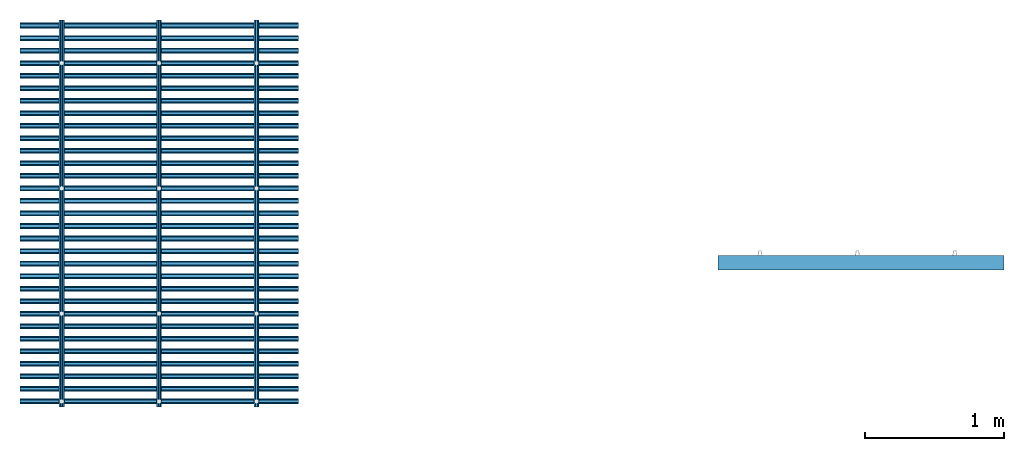
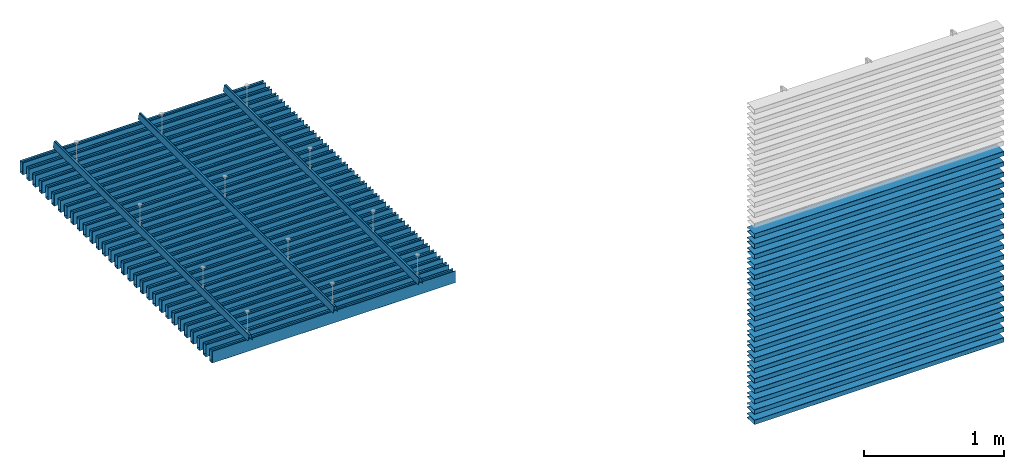
# One storey, part 1 of 3: 53 members, 3 elements without a shape of their own.
"""IFC2X3 building model written with IfcOpenShell, lengths in millimetres."""

from ifc_helpers import new_model, entity, si_unit, converted_unit, derived_unit, direction, frame, frame_2d, origin, place, context, subcontext, project, spatial, polyline, circle_curve, parameter, trimmed, segment, composite_curve, outline, extrude, source, transform, mapped, material, type_object, type_shapes, element, aggregate, save


model = new_model("IFC2X3")

# Units and contexts
model_context = context("Model", 3, precision=0.01, world=origin(), true_north=direction((6.12303176911189e-17, 1.0)))
body_context = subcontext(model_context, "Body", "Model", "MODEL_VIEW")
ifc_project = project(units=[si_unit("LENGTHUNIT", "METRE", prefix="MILLI"), si_unit("AREAUNIT", "SQUARE_METRE"), si_unit("VOLUMEUNIT", "CUBIC_METRE"), converted_unit("PLANEANGLEUNIT", "DEGREE", entity("IfcRatioMeasure", 0.0174532925199433), si_unit("PLANEANGLEUNIT", "RADIAN"), dimensions=[0, 0, 0, 0, 0, 0, 0]), si_unit("MASSUNIT", "GRAM", prefix="KILO"), derived_unit("MASSDENSITYUNIT", [(si_unit("MASSUNIT", "GRAM", prefix="KILO"), 1), (si_unit("LENGTHUNIT", "METRE"), -3)]), derived_unit("MOMENTOFINERTIAUNIT", [(si_unit("LENGTHUNIT", "METRE"), 4)]), si_unit("TIMEUNIT", "SECOND"), si_unit("FREQUENCYUNIT", "HERTZ"), si_unit("THERMODYNAMICTEMPERATUREUNIT", "DEGREE_CELSIUS"), derived_unit("THERMALTRANSMITTANCEUNIT", [(si_unit("MASSUNIT", "GRAM", prefix="KILO"), 1), (si_unit("THERMODYNAMICTEMPERATUREUNIT", "KELVIN"), -1), (si_unit("TIMEUNIT", "SECOND"), -3)]), derived_unit("VOLUMETRICFLOWRATEUNIT", [(si_unit("LENGTHUNIT", "METRE"), 3), (si_unit("TIMEUNIT", "SECOND"), -1)]), si_unit("ELECTRICCURRENTUNIT", "AMPERE"), si_unit("ELECTRICVOLTAGEUNIT", "VOLT"), si_unit("POWERUNIT", "WATT"), si_unit("FORCEUNIT", "NEWTON", prefix="KILO"), si_unit("ILLUMINANCEUNIT", "LUX"), si_unit("LUMINOUSFLUXUNIT", "LUMEN"), si_unit("LUMINOUSINTENSITYUNIT", "CANDELA"), derived_unit("USERDEFINED", [(si_unit("MASSUNIT", "GRAM", prefix="KILO"), -1), (si_unit("LENGTHUNIT", "METRE"), -2), (si_unit("TIMEUNIT", "SECOND"), 3), (si_unit("LUMINOUSFLUXUNIT", "LUMEN"), 1)]), derived_unit("LINEARVELOCITYUNIT", [(si_unit("LENGTHUNIT", "METRE"), 1), (si_unit("TIMEUNIT", "SECOND"), -1)]), si_unit("PRESSUREUNIT", "PASCAL"), derived_unit("USERDEFINED", [(si_unit("LENGTHUNIT", "METRE"), -2), (si_unit("MASSUNIT", "GRAM", prefix="KILO"), 1), (si_unit("TIMEUNIT", "SECOND"), -2)]), derived_unit("LINEARFORCEUNIT", [(si_unit("MASSUNIT", "GRAM", prefix="KILO"), 1), (si_unit("LENGTHUNIT", "METRE"), 1), (si_unit("TIMEUNIT", "SECOND"), -2), (si_unit("LENGTHUNIT", "METRE"), -1)]), derived_unit("PLANARFORCEUNIT", [(si_unit("MASSUNIT", "GRAM", prefix="KILO"), 1), (si_unit("LENGTHUNIT", "METRE"), 1), (si_unit("TIMEUNIT", "SECOND"), -2), (si_unit("LENGTHUNIT", "METRE"), -2)])], contexts=[model_context])

# Site, building, storey
site_placement = place(None, origin())
site = spatial("IfcSite", under=ifc_project, at=site_placement, CompositionType="ELEMENT")
building_placement = place(site_placement, origin())
building = spatial("IfcBuilding", under=site, at=building_placement, CompositionType="ELEMENT")
storey_placement = place(building_placement, origin())
storey = spatial("IfcBuildingStorey", under=building, at=storey_placement, Name="Level 1", CompositionType="ELEMENT", Elevation=0.0)

# Roof, members
curtain_wall_type_1 = type_object("IfcCurtainWallType", PredefinedType="NOTDEFINED")
roof_1_placement = place(storey_placement, origin())
roof_1 = element("IfcRoof", 1, at=roof_1_placement, inside=storey, type_object=curtain_wall_type_1, ShapeType="NOTDEFINED")
ifc_material = material(Name="NBS_PolyesterFibrePET_White")
member_type_1 = type_object("IfcMemberType", PredefinedType="MULLION", material=ifc_material)
shared_shape_1 = source(origin(), body_context, "Body", "SweptSolid", [
    extrude(outline(composite_curve([segment(polyline([(-58.2172353514992, -20.0), (41.5064366235799, -20.0)]), True, "CONTINUOUS"), segment(trimmed(circle_curve(frame_2d((41.5064366235799, -17.2947666541993), x_axis=(0.0, -1.0)), 2.70523334580068), [parameter(0.0)], [parameter(144.999999521531)], True, "PARAMETER"), True, "CONTINUOUS"), segment(polyline([(43.0580947440677, -15.0787692416656), (35.4091908097754, -9.72294895264017)]), True, "CONTINUOUS"), segment(polyline([(35.4091908097754, -9.72294895264017), (34.1473226498031, -11.525083450076)]), True, "CONTINUOUS"), segment(polyline([(34.1473226498031, -11.5250834500759), (41.0304174033758, -16.3446783684007)]), True, "CONTINUOUS"), segment(trimmed(circle_curve(frame_2d((40.5715562488225, -17.0), x_axis=(0.573576443191669, 0.819152039499135)), 0.800000000000003), [parameter(215.000000478469)], [parameter(0.0)], True, "PARAMETER"), False, "CONTINUOUS"), segment(polyline([(40.5715562488225, -17.8), (-57.9019277093083, -17.7999999999998)]), True, "CONTINUOUS"), segment(trimmed(circle_curve(frame_2d((-57.9019277093082, -17.0), x_axis=(0.0, -1.0)), 0.800000000000006), [parameter(270.000000000002)], [parameter(0.0)], True, "PARAMETER"), False, "CONTINUOUS"), segment(polyline([(-58.7019277093083, -17.0), (-58.7019277093082, 17.0)]), True, "CONTINUOUS"), segment(trimmed(circle_curve(frame_2d((-57.9019277093083, 17.0), x_axis=(-1.0, 0.0)), 0.800000000000007), [parameter(270.000000000002)], [parameter(0.0)], True, "PARAMETER"), False, "CONTINUOUS"), segment(polyline([(-57.9019277093083, 17.7999999999998), (40.5715562488224, 17.8)]), True, "CONTINUOUS"), segment(trimmed(circle_curve(frame_2d((40.5715562488224, 17.0), x_axis=(0.0, 1.0)), 0.8), [parameter(215.000000478469)], [parameter(0.0)], True, "PARAMETER"), False, "CONTINUOUS"), segment(polyline([(41.0304174033758, 16.3446783684007), (34.147322649803, 11.5250834500759)]), True, "CONTINUOUS"), segment(polyline([(34.147322649803, 11.5250834500759), (35.4091908097753, 9.72294895264016)]), True, "CONTINUOUS"), segment(polyline([(35.4091908097753, 9.72294895264017), (43.0580947440676, 15.0787692416656)]), True, "CONTINUOUS"), segment(trimmed(circle_curve(frame_2d((41.5064366235798, 17.2947666541993), x_axis=(0.573576443191662, -0.819152039499143)), 2.70523334580069), [parameter(0.0)], [parameter(144.999999521532)], True, "PARAMETER"), True, "CONTINUOUS"), segment(polyline([(41.5064366235798, 20.0), (-58.2172353514993, 20.0)]), True, "CONTINUOUS"), segment(trimmed(circle_curve(frame_2d((-58.2172353514992, 17.3153076421907), x_axis=(0.0, 1.0)), 2.68469235780906), [parameter(0.0)], [parameter(89.9999999999993)], True, "PARAMETER"), True, "CONTINUOUS"), segment(polyline([(-60.9019277093082, 17.3153076421908), (-60.9019277093083, -17.3153076421908)]), True, "CONTINUOUS"), segment(trimmed(circle_curve(frame_2d((-58.2172353514992, -17.3153076421908), x_axis=(-1.0, 0.0)), 2.68469235780904), [parameter(0.0)], [parameter(90.0000000000005)], True, "PARAMETER"), True, "CONTINUOUS")], self_intersect=False)), frame((0.0, 44.2095636081343, -2000.0), z_axis=(0.0, 0.0, 1.0), x_axis=(0.0, -1.0, 0.0)), (0.0, 0.0, 1.0), 2000.0),
])
type_shapes(member_type_1, [shared_shape_1])
member_1_placement = place(storey_placement, frame((-2234.09760171864, 2922.18403114667, 3000.0), z_axis=(-1.0, 0.0, 0.0), x_axis=(0.0, 1.0, 0.0)))
member_1 = element("IfcMember", 2, at=member_1_placement, type_object=member_type_1, material=ifc_material, context=body_context, shape_type="MappedRepresentation", body=[
    mapped(shared_shape_1, transform((0.0, 0.0, 0.0), scale=1.0)),
])
member_2_placement = place(storey_placement, frame((-2234.09760171864, 3012.18403114667, 3000.0), z_axis=(-1.0, 0.0, 0.0), x_axis=(0.0, 1.0, 0.0)))
member_2 = element("IfcMember", 3, at=member_2_placement, type_object=member_type_1, material=ifc_material, context=body_context, shape_type="MappedRepresentation", body=[
    mapped(shared_shape_1, transform((0.0, 0.0, 0.0), scale=1.0)),
])
member_3_placement = place(storey_placement, frame((-2234.09760171864, 3102.18403114667, 3000.0), z_axis=(-1.0, 0.0, 0.0), x_axis=(0.0, 1.0, 0.0)))
member_3 = element("IfcMember", 4, at=member_3_placement, type_object=member_type_1, material=ifc_material, context=body_context, shape_type="MappedRepresentation", body=[
    mapped(shared_shape_1, transform((0.0, 0.0, 0.0), scale=1.0)),
])
member_4_placement = place(storey_placement, frame((-2234.09760171864, 3192.18403114667, 3000.0), z_axis=(-1.0, 0.0, 0.0), x_axis=(0.0, 1.0, 0.0)))
member_4 = element("IfcMember", 5, at=member_4_placement, type_object=member_type_1, material=ifc_material, context=body_context, shape_type="MappedRepresentation", body=[
    mapped(shared_shape_1, transform((0.0, 0.0, 0.0), scale=1.0)),
])
member_5_placement = place(storey_placement, frame((-2234.09760171864, 3282.18403114667, 3000.0), z_axis=(-1.0, 0.0, 0.0), x_axis=(0.0, 1.0, 0.0)))
member_5 = element("IfcMember", 6, at=member_5_placement, type_object=member_type_1, material=ifc_material, context=body_context, shape_type="MappedRepresentation", body=[
    mapped(shared_shape_1, transform((0.0, 0.0, 0.0), scale=1.0)),
])
member_6_placement = place(storey_placement, frame((-2234.09760171864, 3372.18403114667, 3000.0), z_axis=(-1.0, 0.0, 0.0), x_axis=(0.0, 1.0, 0.0)))
member_6 = element("IfcMember", 7, at=member_6_placement, type_object=member_type_1, material=ifc_material, context=body_context, shape_type="MappedRepresentation", body=[
    mapped(shared_shape_1, transform((0.0, 0.0, 0.0), scale=1.0)),
])
member_7_placement = place(storey_placement, frame((-2234.09760171864, 3462.18403114667, 3000.0), z_axis=(-1.0, 0.0, 0.0), x_axis=(0.0, 1.0, 0.0)))
member_7 = element("IfcMember", 8, at=member_7_placement, type_object=member_type_1, material=ifc_material, context=body_context, shape_type="MappedRepresentation", body=[
    mapped(shared_shape_1, transform((0.0, 0.0, 0.0), scale=1.0)),
])
member_8_placement = place(storey_placement, frame((-2234.09760171864, 3552.18403114667, 3000.0), z_axis=(-1.0, 0.0, 0.0), x_axis=(0.0, 1.0, 0.0)))
member_8 = element("IfcMember", 9, at=member_8_placement, type_object=member_type_1, material=ifc_material, context=body_context, shape_type="MappedRepresentation", body=[
    mapped(shared_shape_1, transform((0.0, 0.0, 0.0), scale=1.0)),
])
member_9_placement = place(storey_placement, frame((-2234.09760171864, 3642.18403114667, 3000.0), z_axis=(-1.0, 0.0, 0.0), x_axis=(0.0, 1.0, 0.0)))
member_9 = element("IfcMember", 10, at=member_9_placement, type_object=member_type_1, material=ifc_material, context=body_context, shape_type="MappedRepresentation", body=[
    mapped(shared_shape_1, transform((0.0, 0.0, 0.0), scale=1.0)),
])
member_10_placement = place(storey_placement, frame((-2234.09760171864, 3732.18403114667, 3000.0), z_axis=(-1.0, 0.0, 0.0), x_axis=(0.0, 1.0, 0.0)))
member_10 = element("IfcMember", 11, at=member_10_placement, type_object=member_type_1, material=ifc_material, context=body_context, shape_type="MappedRepresentation", body=[
    mapped(shared_shape_1, transform((0.0, 0.0, 0.0), scale=1.0)),
])
member_11_placement = place(storey_placement, frame((-2234.09760171864, 3822.18403114667, 3000.0), z_axis=(-1.0, 0.0, 0.0), x_axis=(0.0, 1.0, 0.0)))
member_11 = element("IfcMember", 12, at=member_11_placement, type_object=member_type_1, material=ifc_material, context=body_context, shape_type="MappedRepresentation", body=[
    mapped(shared_shape_1, transform((0.0, 0.0, 0.0), scale=1.0)),
])
member_12_placement = place(storey_placement, frame((-2234.09760171864, 3912.18403114667, 3000.0), z_axis=(-1.0, 0.0, 0.0), x_axis=(0.0, 1.0, 0.0)))
member_12 = element("IfcMember", 13, at=member_12_placement, type_object=member_type_1, material=ifc_material, context=body_context, shape_type="MappedRepresentation", body=[
    mapped(shared_shape_1, transform((0.0, 0.0, 0.0), scale=1.0)),
])
member_13_placement = place(storey_placement, frame((-2234.09760171864, 4002.18403114667, 3000.0), z_axis=(-1.0, 0.0, 0.0), x_axis=(0.0, 1.0, 0.0)))
member_13 = element("IfcMember", 14, at=member_13_placement, type_object=member_type_1, material=ifc_material, context=body_context, shape_type="MappedRepresentation", body=[
    mapped(shared_shape_1, transform((0.0, 0.0, 0.0), scale=1.0)),
])
member_14_placement = place(storey_placement, frame((-2234.09760171864, 4092.18403114667, 3000.0), z_axis=(-1.0, 0.0, 0.0), x_axis=(0.0, 1.0, 0.0)))
member_14 = element("IfcMember", 15, at=member_14_placement, type_object=member_type_1, material=ifc_material, context=body_context, shape_type="MappedRepresentation", body=[
    mapped(shared_shape_1, transform((0.0, 0.0, 0.0), scale=1.0)),
])
member_15_placement = place(storey_placement, frame((-2234.09760171864, 4182.18403114667, 3000.0), z_axis=(-1.0, 0.0, 0.0), x_axis=(0.0, 1.0, 0.0)))
member_15 = element("IfcMember", 16, at=member_15_placement, type_object=member_type_1, material=ifc_material, context=body_context, shape_type="MappedRepresentation", body=[
    mapped(shared_shape_1, transform((0.0, 0.0, 0.0), scale=1.0)),
])
member_16_placement = place(storey_placement, frame((-2234.09760171864, 4272.18403114667, 3000.0), z_axis=(-1.0, 0.0, 0.0), x_axis=(0.0, 1.0, 0.0)))
member_16 = element("IfcMember", 17, at=member_16_placement, type_object=member_type_1, material=ifc_material, context=body_context, shape_type="MappedRepresentation", body=[
    mapped(shared_shape_1, transform((0.0, 0.0, 0.0), scale=1.0)),
])
member_17_placement = place(storey_placement, frame((-2234.09760171864, 4362.18403114667, 3000.0), z_axis=(-1.0, 0.0, 0.0), x_axis=(0.0, 1.0, 0.0)))
member_17 = element("IfcMember", 18, at=member_17_placement, type_object=member_type_1, material=ifc_material, context=body_context, shape_type="MappedRepresentation", body=[
    mapped(shared_shape_1, transform((0.0, 0.0, 0.0), scale=1.0)),
])
member_18_placement = place(storey_placement, frame((-2234.09760171864, 4452.18403114667, 3000.0), z_axis=(-1.0, 0.0, 0.0), x_axis=(0.0, 1.0, 0.0)))
member_18 = element("IfcMember", 19, at=member_18_placement, type_object=member_type_1, material=ifc_material, context=body_context, shape_type="MappedRepresentation", body=[
    mapped(shared_shape_1, transform((0.0, 0.0, 0.0), scale=1.0)),
])
member_19_placement = place(storey_placement, frame((-2234.09760171864, 4542.18403114667, 3000.0), z_axis=(-1.0, 0.0, 0.0), x_axis=(0.0, 1.0, 0.0)))
member_19 = element("IfcMember", 20, at=member_19_placement, type_object=member_type_1, material=ifc_material, context=body_context, shape_type="MappedRepresentation", body=[
    mapped(shared_shape_1, transform((0.0, 0.0, 0.0), scale=1.0)),
])
member_20_placement = place(storey_placement, frame((-2234.09760171864, 2382.18403114667, 3000.0), z_axis=(-1.0, 0.0, 0.0), x_axis=(0.0, 1.0, 0.0)))
member_20 = element("IfcMember", 21, at=member_20_placement, type_object=member_type_1, material=ifc_material, context=body_context, shape_type="MappedRepresentation", body=[
    mapped(shared_shape_1, transform((0.0, 0.0, 0.0), scale=1.0)),
])
member_21_placement = place(storey_placement, frame((-2234.09760171864, 2472.18403114667, 3000.0), z_axis=(-1.0, 0.0, 0.0), x_axis=(0.0, 1.0, 0.0)))
member_21 = element("IfcMember", 22, at=member_21_placement, type_object=member_type_1, material=ifc_material, context=body_context, shape_type="MappedRepresentation", body=[
    mapped(shared_shape_1, transform((0.0, 0.0, 0.0), scale=1.0)),
])
member_22_placement = place(storey_placement, frame((-2234.09760171864, 2562.18403114667, 3000.0), z_axis=(-1.0, 0.0, 0.0), x_axis=(0.0, 1.0, 0.0)))
member_22 = element("IfcMember", 23, at=member_22_placement, type_object=member_type_1, material=ifc_material, context=body_context, shape_type="MappedRepresentation", body=[
    mapped(shared_shape_1, transform((0.0, 0.0, 0.0), scale=1.0)),
])
member_23_placement = place(storey_placement, frame((-2234.09760171864, 2652.18403114667, 3000.0), z_axis=(-1.0, 0.0, 0.0), x_axis=(0.0, 1.0, 0.0)))
member_23 = element("IfcMember", 24, at=member_23_placement, type_object=member_type_1, material=ifc_material, context=body_context, shape_type="MappedRepresentation", body=[
    mapped(shared_shape_1, transform((0.0, 0.0, 0.0), scale=1.0)),
])
member_24_placement = place(storey_placement, frame((-2234.09760171864, 2742.18403114667, 3000.0), z_axis=(-1.0, 0.0, 0.0), x_axis=(0.0, 1.0, 0.0)))
member_24 = element("IfcMember", 25, at=member_24_placement, type_object=member_type_1, material=ifc_material, context=body_context, shape_type="MappedRepresentation", body=[
    mapped(shared_shape_1, transform((0.0, 0.0, 0.0), scale=1.0)),
])
member_25_placement = place(storey_placement, frame((-2234.09760171864, 2832.18403114667, 3000.0), z_axis=(-1.0, 0.0, 0.0), x_axis=(0.0, 1.0, 0.0)))
member_25 = element("IfcMember", 26, at=member_25_placement, type_object=member_type_1, material=ifc_material, context=body_context, shape_type="MappedRepresentation", body=[
    mapped(shared_shape_1, transform((0.0, 0.0, 0.0), scale=1.0)),
])
member_26_placement = place(storey_placement, frame((-2234.09760171864, 4632.18403114667, 3000.0), z_axis=(-1.0, 0.0, 0.0), x_axis=(0.0, 1.0, 0.0)))
member_26 = element("IfcMember", 27, at=member_26_placement, type_object=member_type_1, material=ifc_material, context=body_context, shape_type="MappedRepresentation", body=[
    mapped(shared_shape_1, transform((0.0, 0.0, 0.0), scale=1.0)),
])
member_27_placement = place(storey_placement, frame((-2234.09760171864, 4722.18403114667, 3000.0), z_axis=(-1.0, 0.0, 0.0), x_axis=(0.0, 1.0, 0.0)))
member_27 = element("IfcMember", 28, at=member_27_placement, type_object=member_type_1, material=ifc_material, context=body_context, shape_type="MappedRepresentation", body=[
    mapped(shared_shape_1, transform((0.0, 0.0, 0.0), scale=1.0)),
])
member_28_placement = place(storey_placement, frame((-2234.09760171864, 4812.18403114667, 3000.0), z_axis=(-1.0, 0.0, 0.0), x_axis=(0.0, 1.0, 0.0)))
member_28 = element("IfcMember", 29, at=member_28_placement, type_object=member_type_1, material=ifc_material, context=body_context, shape_type="MappedRepresentation", body=[
    mapped(shared_shape_1, transform((0.0, 0.0, 0.0), scale=1.0)),
])
member_29_placement = place(storey_placement, frame((-2234.09760171864, 4902.18403114667, 3000.0), z_axis=(-1.0, 0.0, 0.0), x_axis=(0.0, 1.0, 0.0)))
member_29 = element("IfcMember", 30, at=member_29_placement, type_object=member_type_1, material=ifc_material, context=body_context, shape_type="MappedRepresentation", body=[
    mapped(shared_shape_1, transform((0.0, 0.0, 0.0), scale=1.0)),
])
member_30_placement = place(storey_placement, frame((-2234.09760171864, 4992.18403114667, 3000.0), z_axis=(-1.0, 0.0, 0.0), x_axis=(0.0, 1.0, 0.0)))
member_30 = element("IfcMember", 31, at=member_30_placement, type_object=member_type_1, material=ifc_material, context=body_context, shape_type="MappedRepresentation", body=[
    mapped(shared_shape_1, transform((0.0, 0.0, 0.0), scale=1.0)),
])
member_31_placement = place(storey_placement, frame((-2234.09760171864, 5082.18403114667, 3000.0), z_axis=(-1.0, 0.0, 0.0), x_axis=(0.0, 1.0, 0.0)))
member_31 = element("IfcMember", 32, at=member_31_placement, type_object=member_type_1, material=ifc_material, context=body_context, shape_type="MappedRepresentation", body=[
    mapped(shared_shape_1, transform((0.0, 0.0, 0.0), scale=1.0)),
])
aggregate(roof_1, [member_1, member_2, member_3, member_4, member_5, member_6, member_7, member_8, member_9, member_10, member_11, member_12, member_13, member_14, member_15, member_16, member_17, member_18, member_19, member_20, member_21, member_22, member_23, member_24, member_25, member_26, member_27, member_28, member_29, member_30, member_31])

curtain_wall_type_2 = type_object("IfcCurtainWallType", PredefinedType="NOTDEFINED")
roof_2_placement = place(storey_placement, origin())
roof_2 = element("IfcRoof", 33, at=roof_2_placement, inside=storey, type_object=curtain_wall_type_2, ShapeType="NOTDEFINED")
member_type_2 = type_object("IfcMemberType", PredefinedType="MULLION", material=ifc_material)
shared_shape_2 = source(origin(), body_context, "Body", "SweptSolid", [
    extrude(outline(composite_curve([segment(polyline([(-5.91172214990856, -23.0797556701551), (5.91172214990867, -23.0797556701551)]), True, "CONTINUOUS"), segment(trimmed(circle_curve(frame_2d((5.91172214990869, -19.5797556701551), x_axis=(0.0, -1.0)), 3.5), [parameter(0.0)], [parameter(79.9891974524564)], True, "PARAMETER"), True, "CONTINUOUS"), segment(polyline([(9.35843463547985, -20.1881741460481), (18.0537610900885, 29.0711620587445)]), True, "CONTINUOUS"), segment(polyline([(18.0537610900885, 29.0711620587445), (17.1182248440038, 29.236304216487)]), True, "CONTINUOUS"), segment(polyline([(17.1182248440038, 29.236304216487), (14.1859952637154, 12.6251184859606)]), True, "CONTINUOUS"), segment(polyline([(14.1859952637154, 12.6251184859606), (13.2359636633338, 12.6251184859606)]), True, "CONTINUOUS"), segment(polyline([(13.2359636633338, 12.6251184859606), (7.63365181881013, -19.1121790282936)]), True, "CONTINUOUS"), segment(trimmed(circle_curve(frame_2d((5.17171432911645, -18.6775944026558), x_axis=(0.984774995877474, -0.173833850255129)), 2.5), [parameter(280.010802547544)], [parameter(0.0)], True, "PARAMETER"), False, "CONTINUOUS"), segment(polyline([(5.17171432911645, -21.1775944026558), (-5.17171432911632, -21.1775944026558)]), True, "CONTINUOUS"), segment(trimmed(circle_curve(frame_2d((-5.17171432911631, -18.6775944026558), x_axis=(0.0, -1.0)), 2.49999999999999), [parameter(280.010802547544)], [parameter(0.0)], True, "PARAMETER"), False, "CONTINUOUS"), segment(polyline([(-7.63365181880999, -19.1121790282936), (-13.2359636633339, 12.6251184859605)]), True, "CONTINUOUS"), segment(polyline([(-13.2359636633339, 12.6251184859605), (-14.1859952637155, 12.6251184859605)]), True, "CONTINUOUS"), segment(polyline([(-14.1859952637155, 12.6251184859605), (-17.118224844004, 29.2363042164869)]), True, "CONTINUOUS"), segment(polyline([(-17.118224844004, 29.2363042164869), (-18.0537610900887, 29.0711620587444)]), True, "CONTINUOUS"), segment(polyline([(-18.0537610900887, 29.0711620587444), (-9.3584346354797, -20.1881741460481)]), True, "CONTINUOUS"), segment(trimmed(circle_curve(frame_2d((-5.91172214990854, -19.5797556701551), x_axis=(-0.984774995877476, -0.173833850255114)), 3.5), [parameter(0.0)], [parameter(79.989197452456)], True, "PARAMETER"), True, "CONTINUOUS")], self_intersect=False)), frame((0.0, -29.2427591458207, -2780.0)), (0.0, 0.0, 1.0), 2780.0),
])
type_shapes(member_type_2, [shared_shape_2])
member_32_placement = place(storey_placement, frame((-1934.10736368488, 5121.86013651194, 3000.0), z_axis=(0.0, 1.0, 0.0), x_axis=(1.0, 0.0, 0.0)))
member_32 = element("IfcMember", 34, at=member_32_placement, type_object=member_type_2, material=ifc_material, context=body_context, shape_type="MappedRepresentation", body=[
    mapped(shared_shape_2, transform((0.0, 0.0, 0.0), scale=1.0)),
])
member_33_placement = place(storey_placement, frame((-1234.10736368488, 5121.86013651194, 3000.0), z_axis=(0.0, 1.0, 0.0), x_axis=(1.0, 0.0, 0.0)))
member_33 = element("IfcMember", 35, at=member_33_placement, type_object=member_type_2, material=ifc_material, context=body_context, shape_type="MappedRepresentation", body=[
    mapped(shared_shape_2, transform((0.0, 0.0, 0.0), scale=1.0)),
])
member_34_placement = place(storey_placement, frame((-534.107363684878, 5121.86013651194, 3000.0), z_axis=(0.0, 1.0, 0.0), x_axis=(1.0, 0.0, 0.0)))
member_34 = element("IfcMember", 36, at=member_34_placement, type_object=member_type_2, material=ifc_material, context=body_context, shape_type="MappedRepresentation", body=[
    mapped(shared_shape_2, transform((0.0, 0.0, 0.0), scale=1.0)),
])
aggregate(roof_2, [member_32, member_33, member_34])

# Curtain wall, members
curtain_wall_type_3 = type_object("IfcCurtainWallType", PredefinedType="NOTDEFINED")
curtain_wall_placement = place(storey_placement, origin())
curtain_wall = element("IfcCurtainWall", 37, at=curtain_wall_placement, inside=storey, type_object=curtain_wall_type_3)
member_type_3 = type_object("IfcMemberType", PredefinedType="MULLION", material=ifc_material)
shared_shape_3 = source(origin(), body_context, "Body", "SweptSolid", [
    extrude(outline(composite_curve([segment(polyline([(-58.2172353514992, -20.0), (41.5064366235799, -20.0)]), True, "CONTINUOUS"), segment(trimmed(circle_curve(frame_2d((41.5064366235799, -17.2947666541993), x_axis=(0.0, -1.0)), 2.70523334580068), [parameter(0.0)], [parameter(144.999999521531)], True, "PARAMETER"), True, "CONTINUOUS"), segment(polyline([(43.0580947440677, -15.0787692416656), (35.4091908097754, -9.72294895264017)]), True, "CONTINUOUS"), segment(polyline([(35.4091908097754, -9.72294895264017), (34.1473226498031, -11.525083450076)]), True, "CONTINUOUS"), segment(polyline([(34.1473226498031, -11.5250834500759), (41.0304174033758, -16.3446783684007)]), True, "CONTINUOUS"), segment(trimmed(circle_curve(frame_2d((40.5715562488225, -17.0), x_axis=(0.573576443191669, 0.819152039499135)), 0.800000000000003), [parameter(215.000000478469)], [parameter(0.0)], True, "PARAMETER"), False, "CONTINUOUS"), segment(polyline([(40.5715562488225, -17.8), (-57.9019277093083, -17.7999999999998)]), True, "CONTINUOUS"), segment(trimmed(circle_curve(frame_2d((-57.9019277093082, -17.0), x_axis=(0.0, -1.0)), 0.800000000000006), [parameter(270.000000000002)], [parameter(0.0)], True, "PARAMETER"), False, "CONTINUOUS"), segment(polyline([(-58.7019277093083, -17.0), (-58.7019277093082, 17.0)]), True, "CONTINUOUS"), segment(trimmed(circle_curve(frame_2d((-57.9019277093083, 17.0), x_axis=(-1.0, 0.0)), 0.800000000000007), [parameter(270.000000000002)], [parameter(0.0)], True, "PARAMETER"), False, "CONTINUOUS"), segment(polyline([(-57.9019277093083, 17.7999999999998), (40.5715562488224, 17.8)]), True, "CONTINUOUS"), segment(trimmed(circle_curve(frame_2d((40.5715562488224, 17.0), x_axis=(0.0, 1.0)), 0.8), [parameter(215.000000478469)], [parameter(0.0)], True, "PARAMETER"), False, "CONTINUOUS"), segment(polyline([(41.0304174033758, 16.3446783684007), (34.147322649803, 11.5250834500759)]), True, "CONTINUOUS"), segment(polyline([(34.147322649803, 11.5250834500759), (35.4091908097753, 9.72294895264016)]), True, "CONTINUOUS"), segment(polyline([(35.4091908097753, 9.72294895264017), (43.0580947440676, 15.0787692416656)]), True, "CONTINUOUS"), segment(trimmed(circle_curve(frame_2d((41.5064366235798, 17.2947666541993), x_axis=(0.573576443191662, -0.819152039499143)), 2.70523334580069), [parameter(0.0)], [parameter(144.999999521532)], True, "PARAMETER"), True, "CONTINUOUS"), segment(polyline([(41.5064366235798, 20.0), (-58.2172353514993, 20.0)]), True, "CONTINUOUS"), segment(trimmed(circle_curve(frame_2d((-58.2172353514992, 17.3153076421907), x_axis=(0.0, 1.0)), 2.68469235780906), [parameter(0.0)], [parameter(89.9999999999993)], True, "PARAMETER"), True, "CONTINUOUS"), segment(polyline([(-60.9019277093082, 17.3153076421908), (-60.9019277093083, -17.3153076421908)]), True, "CONTINUOUS"), segment(trimmed(circle_curve(frame_2d((-58.2172353514992, -17.3153076421908), x_axis=(-1.0, 0.0)), 2.68469235780904), [parameter(0.0)], [parameter(90.0000000000005)], True, "PARAMETER"), True, "CONTINUOUS")], self_intersect=False)), frame((0.0, 44.2095636081343, -2053.04571376474), z_axis=(0.0, 0.0, 1.0), x_axis=(0.0, -1.0, 0.0)), (0.0, 0.0, 1.0), 2053.04571376474),
])
type_shapes(member_type_3, [shared_shape_3])
member_35_placement = place(storey_placement, frame((4834.4582193015, 3430.12593951945, 39.9828435877168), z_axis=(1.0, 0.0, 0.0), x_axis=(0.0, 0.0, 1.0)))
member_35 = element("IfcMember", 38, at=member_35_placement, type_object=member_type_3, material=ifc_material, context=body_context, shape_type="MappedRepresentation", body=[
    mapped(shared_shape_3, transform((0.0, 0.0, 0.0), scale=1.0)),
])
member_36_placement = place(storey_placement, frame((4834.4582193015, 3430.12593951945, 129.982843587717), z_axis=(1.0, 0.0, 0.0), x_axis=(0.0, 0.0, 1.0)))
member_36 = element("IfcMember", 39, at=member_36_placement, type_object=member_type_3, material=ifc_material, context=body_context, shape_type="MappedRepresentation", body=[
    mapped(shared_shape_3, transform((0.0, 0.0, 0.0), scale=1.0)),
])
member_37_placement = place(storey_placement, frame((4834.4582193015, 3430.12593951945, 219.982843587717), z_axis=(1.0, 0.0, 0.0), x_axis=(0.0, 0.0, 1.0)))
member_37 = element("IfcMember", 40, at=member_37_placement, type_object=member_type_3, material=ifc_material, context=body_context, shape_type="MappedRepresentation", body=[
    mapped(shared_shape_3, transform((0.0, 0.0, 0.0), scale=1.0)),
])
member_38_placement = place(storey_placement, frame((4834.4582193015, 3430.12593951945, 309.982843587717), z_axis=(1.0, 0.0, 0.0), x_axis=(0.0, 0.0, 1.0)))
member_38 = element("IfcMember", 41, at=member_38_placement, type_object=member_type_3, material=ifc_material, context=body_context, shape_type="MappedRepresentation", body=[
    mapped(shared_shape_3, transform((0.0, 0.0, 0.0), scale=1.0)),
])
member_39_placement = place(storey_placement, frame((4834.4582193015, 3430.12593951945, 399.982843587717), z_axis=(1.0, 0.0, 0.0), x_axis=(0.0, 0.0, 1.0)))
member_39 = element("IfcMember", 42, at=member_39_placement, type_object=member_type_3, material=ifc_material, context=body_context, shape_type="MappedRepresentation", body=[
    mapped(shared_shape_3, transform((0.0, 0.0, 0.0), scale=1.0)),
])
member_40_placement = place(storey_placement, frame((4834.4582193015, 3430.12593951945, 489.982843587717), z_axis=(1.0, 0.0, 0.0), x_axis=(0.0, 0.0, 1.0)))
member_40 = element("IfcMember", 43, at=member_40_placement, type_object=member_type_3, material=ifc_material, context=body_context, shape_type="MappedRepresentation", body=[
    mapped(shared_shape_3, transform((0.0, 0.0, 0.0), scale=1.0)),
])
member_41_placement = place(storey_placement, frame((4834.4582193015, 3430.12593951945, 579.982843587717), z_axis=(1.0, 0.0, 0.0), x_axis=(0.0, 0.0, 1.0)))
member_41 = element("IfcMember", 44, at=member_41_placement, type_object=member_type_3, material=ifc_material, context=body_context, shape_type="MappedRepresentation", body=[
    mapped(shared_shape_3, transform((0.0, 0.0, 0.0), scale=1.0)),
])
member_42_placement = place(storey_placement, frame((4834.4582193015, 3430.12593951945, 669.982843587717), z_axis=(1.0, 0.0, 0.0), x_axis=(0.0, 0.0, 1.0)))
member_42 = element("IfcMember", 45, at=member_42_placement, type_object=member_type_3, material=ifc_material, context=body_context, shape_type="MappedRepresentation", body=[
    mapped(shared_shape_3, transform((0.0, 0.0, 0.0), scale=1.0)),
])
member_43_placement = place(storey_placement, frame((4834.4582193015, 3430.12593951945, 759.982843587717), z_axis=(1.0, 0.0, 0.0), x_axis=(0.0, 0.0, 1.0)))
member_43 = element("IfcMember", 46, at=member_43_placement, type_object=member_type_3, material=ifc_material, context=body_context, shape_type="MappedRepresentation", body=[
    mapped(shared_shape_3, transform((0.0, 0.0, 0.0), scale=1.0)),
])
member_44_placement = place(storey_placement, frame((4834.4582193015, 3430.12593951945, 849.982843587717), z_axis=(1.0, 0.0, 0.0), x_axis=(0.0, 0.0, 1.0)))
member_44 = element("IfcMember", 47, at=member_44_placement, type_object=member_type_3, material=ifc_material, context=body_context, shape_type="MappedRepresentation", body=[
    mapped(shared_shape_3, transform((0.0, 0.0, 0.0), scale=1.0)),
])
member_45_placement = place(storey_placement, frame((4834.4582193015, 3430.12593951945, 939.982843587717), z_axis=(1.0, 0.0, 0.0), x_axis=(0.0, 0.0, 1.0)))
member_45 = element("IfcMember", 48, at=member_45_placement, type_object=member_type_3, material=ifc_material, context=body_context, shape_type="MappedRepresentation", body=[
    mapped(shared_shape_3, transform((0.0, 0.0, 0.0), scale=1.0)),
])
member_46_placement = place(storey_placement, frame((4834.4582193015, 3430.12593951945, 1029.98284358772), z_axis=(1.0, 0.0, 0.0), x_axis=(0.0, 0.0, 1.0)))
member_46 = element("IfcMember", 49, at=member_46_placement, type_object=member_type_3, material=ifc_material, context=body_context, shape_type="MappedRepresentation", body=[
    mapped(shared_shape_3, transform((0.0, 0.0, 0.0), scale=1.0)),
])
member_47_placement = place(storey_placement, frame((4834.4582193015, 3430.12593951945, 1119.98284358772), z_axis=(1.0, 0.0, 0.0), x_axis=(0.0, 0.0, 1.0)))
member_47 = element("IfcMember", 50, at=member_47_placement, type_object=member_type_3, material=ifc_material, context=body_context, shape_type="MappedRepresentation", body=[
    mapped(shared_shape_3, transform((0.0, 0.0, 0.0), scale=1.0)),
])
member_48_placement = place(storey_placement, frame((4834.4582193015, 3430.12593951945, 1209.98284358772), z_axis=(1.0, 0.0, 0.0), x_axis=(0.0, 0.0, 1.0)))
member_48 = element("IfcMember", 51, at=member_48_placement, type_object=member_type_3, material=ifc_material, context=body_context, shape_type="MappedRepresentation", body=[
    mapped(shared_shape_3, transform((0.0, 0.0, 0.0), scale=1.0)),
])
member_49_placement = place(storey_placement, frame((4834.4582193015, 3430.12593951945, 1299.98284358772), z_axis=(1.0, 0.0, 0.0), x_axis=(0.0, 0.0, 1.0)))
member_49 = element("IfcMember", 52, at=member_49_placement, type_object=member_type_3, material=ifc_material, context=body_context, shape_type="MappedRepresentation", body=[
    mapped(shared_shape_3, transform((0.0, 0.0, 0.0), scale=1.0)),
])
member_50_placement = place(storey_placement, frame((4834.4582193015, 3430.12593951945, 1389.98284358772), z_axis=(1.0, 0.0, 0.0), x_axis=(0.0, 0.0, 1.0)))
member_50 = element("IfcMember", 53, at=member_50_placement, type_object=member_type_3, material=ifc_material, context=body_context, shape_type="MappedRepresentation", body=[
    mapped(shared_shape_3, transform((0.0, 0.0, 0.0), scale=1.0)),
])
member_51_placement = place(storey_placement, frame((4834.4582193015, 3430.12593951945, 1479.98284358772), z_axis=(1.0, 0.0, 0.0), x_axis=(0.0, 0.0, 1.0)))
member_51 = element("IfcMember", 54, at=member_51_placement, type_object=member_type_3, material=ifc_material, context=body_context, shape_type="MappedRepresentation", body=[
    mapped(shared_shape_3, transform((0.0, 0.0, 0.0), scale=1.0)),
])
member_52_placement = place(storey_placement, frame((4834.4582193015, 3430.12593951945, 1569.98284358772), z_axis=(1.0, 0.0, 0.0), x_axis=(0.0, 0.0, 1.0)))
member_52 = element("IfcMember", 55, at=member_52_placement, type_object=member_type_3, material=ifc_material, context=body_context, shape_type="MappedRepresentation", body=[
    mapped(shared_shape_3, transform((0.0, 0.0, 0.0), scale=1.0)),
])
member_53_placement = place(storey_placement, frame((4834.4582193015, 3430.12593951945, 1659.98284358772), z_axis=(1.0, 0.0, 0.0), x_axis=(0.0, 0.0, 1.0)))
member_53 = element("IfcMember", 56, at=member_53_placement, type_object=member_type_3, material=ifc_material, context=body_context, shape_type="MappedRepresentation", body=[
    mapped(shared_shape_3, transform((0.0, 0.0, 0.0), scale=1.0)),
])
aggregate(curtain_wall, [member_35, member_36, member_37, member_38, member_39, member_40, member_41, member_42, member_43, member_44, member_45, member_46, member_47, member_48, member_49, member_50, member_51, member_52, member_53])

save(model, "model.ifc")
